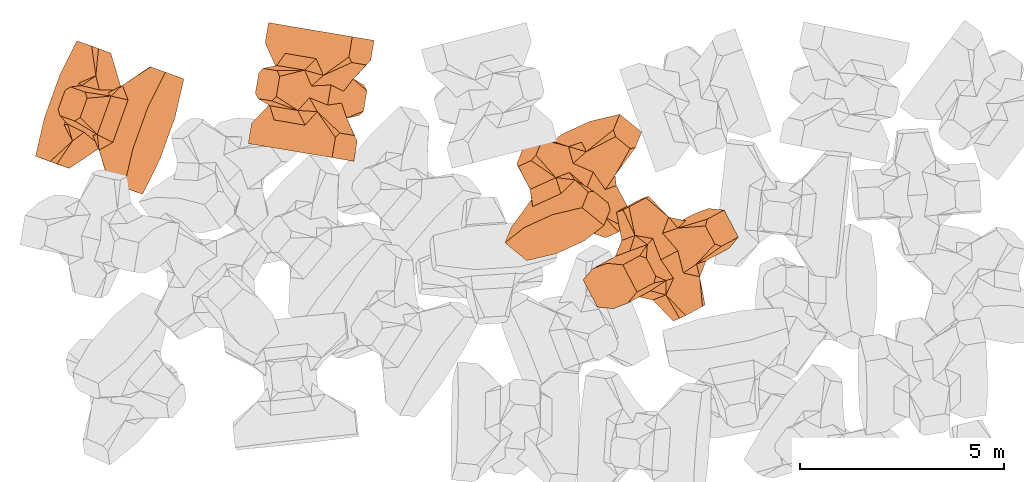
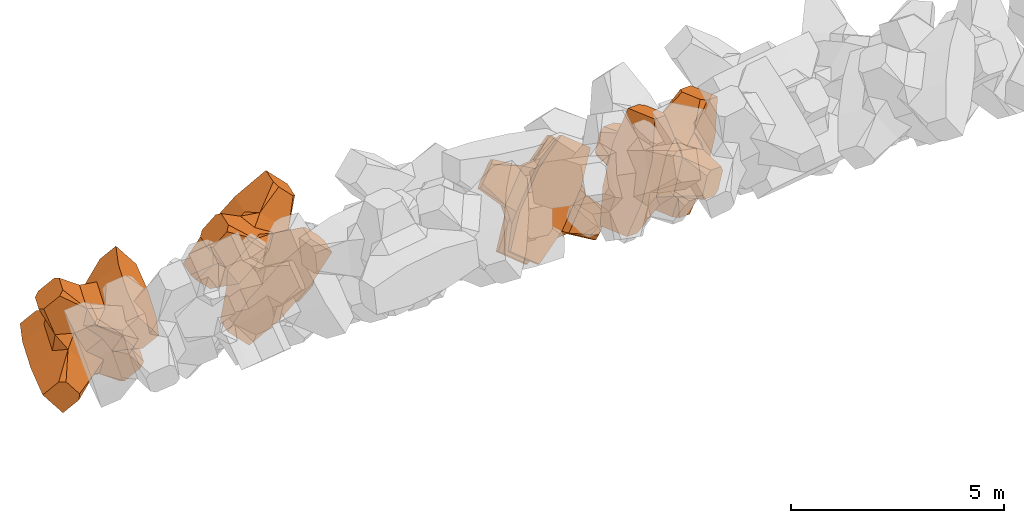
# One storey, part 14 of 17: 4 civil elements.
"""IFC4 building model written with IfcOpenShell, lengths in metres."""

from ifc_helpers import new_model, entity, si_unit, converted_unit, frame, origin_with_axes, origin_2d_with_axis, place, context, subcontext, project, spatial, polygons, element, save


model = new_model("IFC4")

# Units and contexts
model_context = context("Model", 3, precision=1e-05, world=origin_with_axes())
plan_context = context("Plan", 2, precision=1e-05, world=origin_2d_with_axis())
body_context = subcontext(model_context, "Body", "Model", "MODEL_VIEW")
ifc_project = project(units=[si_unit("VOLUMEUNIT", "CUBIC_METRE"), si_unit("LENGTHUNIT", "METRE"), converted_unit("PLANEANGLEUNIT", "degree", entity("IfcReal", 0.0174532925199433), si_unit("PLANEANGLEUNIT", "RADIAN"), dimensions=[0, 0, 0, 0, 0, 0, 0]), si_unit("AREAUNIT", "SQUARE_METRE")], contexts=[model_context, plan_context])

# Site, building, storey
site_placement = place(None, origin_with_axes())
site = spatial("IfcSite", under=ifc_project, at=site_placement)
building_placement = place(site_placement, origin_with_axes())
building = spatial("IfcBuilding", under=site, at=building_placement, Name="Building")
storey_placement = place(building_placement, origin_with_axes())
storey = spatial("IfcBuildingStorey", under=building, at=storey_placement, Name="Storey")

# Civil elements
civil_element_1_placement = place(storey_placement, frame((1.21781599521637, 19.9946975708008, 2.43037390708923), z_axis=(0.604936462853144, -0.22197844929838, -0.764707423762718), x_axis=(0.337829623847278, 0.941188406727842, -0.00596056140921159)))
element("IfcCivilElement", 1, at=civil_element_1_placement, inside=storey, ObjectType="IfcCivilElementType", context=body_context, shape_type="Tessellation", body=[
    polygons([(0.50000011920929, 0.499999940395355, 0.821428716182709), (0.374999821186066, 0.24999988079071, 1.50000023841858), (0.550000011920929, 0.145680576562881, 0.550000131130219), (0.374999821186066, -0.249999940395355, 1.50000023841858), (0.651315808296204, -0.249999940395355, 1.45970560083697e-07), (0.651315808296204, 0.24999988079071, 1.45970560083697e-07), (0.550000011920929, -0.145680651068687, 0.550000131130219), (0.50000011920929, -0.499999940395355, 0.821428716182709), (-0.25, 0.374999672174454, 1.50000023841858), (0.249999970197678, 0.374999672174454, 1.50000023841858), (-0.500000059604645, 0.499999940395355, 0.821428716182709), (-0.550000011920929, 0.824999749660492, 0.550000131130219), (0.550000011920929, 0.824999749660492, 0.550000131130219), (-0.550000011920929, 1.49999964237213, 0.550000131130219), (0.550000011920929, 1.49999964237213, 0.550000131130219), (-0.25, -0.374999910593033, 1.50000023841858), (0.249999970197678, -0.374999910593033, 1.50000023841858), (-0.374999970197678, -0.249999940395355, 1.50000023841858), (-0.374999970197678, 0.24999988079071, 1.50000023841858), (1.5, 0.874999582767487, -0.249999836087227), (1.5, 0.874999582767487, 0.25000011920929), (0.845557510852814, 0.449999779462814, -0.49555516242981), (0.845557510852814, 0.449999779462814, 0.49555516242981), (1.5, 1.49999964237213, -0.374999821186066), (1.5, 1.49999964237213, 0.374999970197678), (1.5, 0.999999701976776, -0.374999821186066), (1.5, 0.999999701976776, 0.374999970197678), (-1.5, 1.49999964237213, -0.374999821186066), (-1.5, 1.49999964237213, 0.374999970197678), (-0.550000011920929, 1.49999964237213, -0.549999833106995), (0.550000011920929, 1.49999964237213, -0.549999833106995), (0.550000011920929, 0.145680576562881, -0.549999833106995), (-0.500000059604645, -0.499999940395355, 0.821428716182709), (-0.550000011920929, -0.145680651068687, 0.550000131130219), (-0.651315808296204, 0.24999988079071, 1.45970560083697e-07), (-0.651315808296204, -0.249999940395355, 1.45970560083697e-07), (-0.550000011920929, 0.145680576562881, 0.550000131130219), (-1.5, 0.874999582767487, 0.25000011920929), (-1.5, 0.874999582767487, -0.249999836087227), (-0.845557391643524, 0.449999779462814, 0.49555516242981), (-0.845557391643524, 0.449999779462814, -0.49555516242981), (-1.5, 0.999999701976776, 0.374999970197678), (-1.5, 0.999999701976776, -0.374999821186066), (-0.550000011920929, 0.145680576562881, -0.549999833106995), (0.550000011920929, -0.824999868869781, 0.550000131130219), (-0.550000011920929, -0.824999868869781, 0.550000131130219), (0.550000011920929, -1.49999964237213, 0.550000131130219), (-0.550000011920929, -1.49999964237213, 0.550000131130219), (1.5, -0.874999821186066, 0.25000011920929), (1.5, -0.874999821186066, -0.249999836087227), (0.845557510852814, -0.449999988079071, 0.49555516242981), (0.845557510852814, -0.449999988079071, -0.49555516242981), (1.5, -1.49999964237213, 0.374999970197678), (1.5, -1.49999964237213, -0.374999821186066), (1.5, -0.99999988079071, 0.374999970197678), (1.5, -0.99999988079071, -0.374999821186066), (0.550000011920929, -1.49999964237213, -0.549999833106995), (-0.550000011920929, -1.49999964237213, -0.549999833106995), (-1.5, -1.49999964237213, -0.374999821186066), (-1.5, -1.49999964237213, 0.374999970197678), (0.550000011920929, -0.145680651068687, -0.549999833106995), (-1.5, -0.874999821186066, -0.249999836087227), (-1.5, -0.874999821186066, 0.25000011920929), (-0.845557391643524, -0.449999988079071, -0.49555516242981), (-0.845557391643524, -0.449999988079071, 0.49555516242981), (-1.5, -0.99999988079071, -0.374999821186066), (-1.5, -0.99999988079071, 0.374999970197678), (-0.550000011920929, -0.145680651068687, -0.549999833106995), (0.50000011920929, -0.499999940395355, -0.821428537368774), (0.374999821186066, -0.249999940395355, -1.49999988079071), (0.374999821186066, 0.24999988079071, -1.49999988079071), (0.50000011920929, 0.499999940395355, -0.821428537368774), (0.249999970197678, 0.374999672174454, -1.49999988079071), (-0.25, 0.374999672174454, -1.49999988079071), (-0.500000059604645, 0.499999940395355, -0.821428537368774), (0.550000011920929, 0.824999749660492, -0.549999833106995), (-0.550000011920929, 0.824999749660492, -0.549999833106995), (0.249999970197678, -0.374999910593033, -1.49999988079071), (-0.25, -0.374999910593033, -1.49999988079071), (-0.374999970197678, -0.249999940395355, -1.49999988079071), (-0.374999970197678, 0.24999988079071, -1.49999988079071), (-0.500000059604645, -0.499999940395355, -0.821428537368774), (-0.550000011920929, -0.824999868869781, -0.549999833106995), (0.550000011920929, -0.824999868869781, -0.549999833106995)], [[[1, 2, 3]], [[3, 2, 4]], [[5, 6, 7]], [[7, 6, 3]], [[7, 3, 8]], [[8, 3, 4]], [[9, 10, 11]], [[11, 10, 1]], [[12, 13, 14]], [[14, 13, 15]], [[16, 17, 18]], [[18, 17, 4]], [[18, 4, 19]], [[19, 4, 2]], [[19, 2, 9]], [[9, 2, 10]], [[20, 21, 22]], [[22, 21, 23]], [[24, 25, 26]], [[26, 25, 27]], [[26, 27, 20]], [[20, 27, 21]], [[23, 27, 13]], [[13, 27, 25]], [[13, 25, 15]], [[28, 29, 30]], [[30, 29, 14]], [[30, 14, 31]], [[31, 14, 15]], [[31, 15, 24]], [[24, 15, 25]], [[21, 27, 23]], [[2, 1, 10]], [[13, 12, 1]], [[1, 12, 11]], [[13, 1, 23]], [[32, 22, 6]], [[6, 22, 23]], [[6, 23, 3]], [[3, 23, 1]], [[33, 18, 34]], [[34, 18, 19]], [[35, 36, 37]], [[37, 36, 34]], [[37, 34, 11]], [[11, 34, 19]], [[38, 39, 40]], [[40, 39, 41]], [[29, 28, 42]], [[42, 28, 43]], [[42, 43, 38]], [[38, 43, 39]], [[14, 29, 12]], [[12, 29, 42]], [[12, 42, 40]], [[40, 42, 38]], [[9, 11, 19]], [[40, 11, 12]], [[37, 40, 35]], [[35, 40, 41]], [[35, 41, 44]], [[11, 40, 37]], [[17, 16, 8]], [[8, 16, 33]], [[45, 46, 47]], [[47, 46, 48]], [[49, 50, 51]], [[51, 50, 52]], [[53, 54, 55]], [[55, 54, 56]], [[55, 56, 49]], [[49, 56, 50]], [[47, 53, 45]], [[45, 53, 55]], [[45, 55, 51]], [[54, 53, 57]], [[57, 53, 47]], [[57, 47, 58]], [[58, 47, 48]], [[58, 48, 59]], [[59, 48, 60]], [[51, 55, 49]], [[17, 8, 4]], [[46, 45, 33]], [[33, 45, 8]], [[51, 8, 45]], [[7, 51, 5]], [[5, 51, 52]], [[5, 52, 61]], [[8, 51, 7]], [[62, 63, 64]], [[64, 63, 65]], [[59, 60, 66]], [[66, 60, 67]], [[66, 67, 62]], [[62, 67, 63]], [[65, 67, 46]], [[46, 67, 60]], [[46, 60, 48]], [[63, 67, 65]], [[18, 33, 16]], [[46, 33, 65]], [[68, 64, 36]], [[36, 64, 65]], [[36, 65, 34]], [[34, 65, 33]], [[69, 70, 61]], [[61, 70, 71]], [[6, 5, 32]], [[32, 5, 61]], [[32, 61, 72]], [[72, 61, 71]], [[73, 74, 72]], [[72, 74, 75]], [[76, 77, 31]], [[31, 77, 30]], [[78, 79, 70]], [[70, 79, 80]], [[70, 80, 71]], [[71, 80, 81]], [[71, 81, 73]], [[73, 81, 74]], [[31, 24, 76]], [[76, 24, 26]], [[76, 26, 22]], [[22, 26, 20]], [[73, 72, 71]], [[77, 76, 75]], [[75, 76, 72]], [[22, 72, 76]], [[72, 22, 32]], [[75, 81, 44]], [[44, 81, 80]], [[36, 35, 68]], [[68, 35, 44]], [[68, 44, 82]], [[82, 44, 80]], [[41, 43, 77]], [[77, 43, 28]], [[77, 28, 30]], [[39, 43, 41]], [[81, 75, 74]], [[77, 75, 41]], [[44, 41, 75]], [[79, 78, 82]], [[82, 78, 69]], [[83, 84, 58]], [[58, 84, 57]], [[52, 56, 84]], [[84, 56, 54]], [[84, 54, 57]], [[50, 56, 52]], [[70, 69, 78]], [[84, 83, 69]], [[69, 83, 82]], [[84, 69, 52]], [[61, 52, 69]], [[58, 59, 83]], [[83, 59, 66]], [[83, 66, 64]], [[64, 66, 62]], [[79, 82, 80]], [[64, 82, 83]], [[82, 64, 68]]], closed=True),
])
civil_element_2_placement = place(storey_placement, frame((6.14419651031494, 20.620777130127, 2.38104557991028), z_axis=(0.710945292411248, -0.119452399341424, -0.693028076985242), x_axis=(-0.683448188492928, 0.11483239265488, -0.720910601422181)))
element("IfcCivilElement", 2, at=civil_element_2_placement, inside=storey, ObjectType="IfcCivilElementType", context=body_context, shape_type="Tessellation", body=[
    polygons([(0.5, 0.500000059604645, 0.821428596973419), (0.374999761581421, 0.249999940395355, 1.49999988079071), (0.549999892711639, 0.145680621266365, 0.550000011920929), (0.374999761581421, -0.250000029802322, 1.49999988079071), (0.651315689086914, -0.250000029802322, 1.45970531661987e-07), (0.651315689086914, 0.249999940395355, 1.45970531661987e-07), (0.549999892711639, -0.145680695772171, 0.550000011920929), (0.5, -0.500000059604645, 0.821428596973419), (-0.249999955296516, 0.374999791383743, 1.49999988079071), (0.249999910593033, 0.374999791383743, 1.49999988079071), (-0.499999940395355, 0.500000059604645, 0.821428596973419), (-0.549999892711639, 0.824999988079071, 0.550000011920929), (0.549999892711639, 0.824999988079071, 0.550000011920929), (-0.549999892711639, 1.5, 0.550000011920929), (0.549999892711639, 1.5, 0.550000011920929), (-0.249999955296516, -0.375, 1.49999988079071), (0.249999910593033, -0.375, 1.49999988079071), (-0.374999910593033, -0.250000029802322, 1.49999988079071), (-0.374999910593033, 0.249999940395355, 1.49999988079071), (1.49999976158142, 0.87499988079071, -0.249999791383743), (1.49999976158142, 0.87499988079071, 0.250000089406967), (0.845557391643524, 0.449999898672104, -0.495555073022842), (0.845557391643524, 0.449999898672104, 0.495555073022842), (1.49999976158142, 1.5, -0.374999761581421), (1.49999976158142, 1.5, 0.374999910593033), (1.49999976158142, 1.0, -0.374999761581421), (1.49999976158142, 1.0, 0.374999910593033), (-1.49999976158142, 1.5, -0.374999761581421), (-1.49999976158142, 1.5, 0.374999910593033), (-0.549999892711639, 1.5, -0.549999713897705), (0.549999892711639, 1.5, -0.549999713897705), (0.549999892711639, 0.145680621266365, -0.549999713897705), (-0.499999940395355, -0.500000059604645, 0.821428596973419), (-0.549999892711639, -0.145680695772171, 0.550000011920929), (-0.651315689086914, 0.249999940395355, 1.45970531661987e-07), (-0.651315689086914, -0.250000029802322, 1.45970531661987e-07), (-0.549999892711639, 0.145680621266365, 0.550000011920929), (-1.49999976158142, 0.87499988079071, 0.250000089406967), (-1.49999976158142, 0.87499988079071, -0.249999791383743), (-0.84555721282959, 0.449999898672104, 0.495555073022842), (-0.84555721282959, 0.449999898672104, -0.495555073022842), (-1.49999976158142, 1.0, 0.374999910593033), (-1.49999976158142, 1.0, -0.374999761581421), (-0.549999892711639, 0.145680621266365, -0.549999713897705), (0.549999892711639, -0.825000107288361, 0.550000011920929), (-0.549999892711639, -0.825000107288361, 0.550000011920929), (0.549999892711639, -1.5, 0.550000011920929), (-0.549999892711639, -1.5, 0.550000011920929), (1.49999976158142, -0.875000059604645, 0.250000089406967), (1.49999976158142, -0.875000059604645, -0.249999791383743), (0.845557391643524, -0.450000137090683, 0.495555073022842), (0.845557391643524, -0.450000137090683, -0.495555073022842), (1.49999976158142, -1.5, 0.374999910593033), (1.49999976158142, -1.5, -0.374999761581421), (1.49999976158142, -1.00000011920929, 0.374999910593033), (1.49999976158142, -1.00000011920929, -0.374999761581421), (0.549999892711639, -1.5, -0.549999713897705), (-0.549999892711639, -1.5, -0.549999713897705), (-1.49999976158142, -1.5, -0.374999761581421), (-1.49999976158142, -1.5, 0.374999910593033), (0.549999892711639, -0.145680695772171, -0.549999713897705), (-1.49999976158142, -0.875000059604645, -0.249999791383743), (-1.49999976158142, -0.875000059604645, 0.250000089406967), (-0.84555721282959, -0.450000137090683, -0.495555073022842), (-0.84555721282959, -0.450000137090683, 0.495555073022842), (-1.49999976158142, -1.00000011920929, -0.374999761581421), (-1.49999976158142, -1.00000011920929, 0.374999910593033), (-0.549999892711639, -0.145680695772171, -0.549999713897705), (0.5, -0.500000059604645, -0.82142835855484), (0.374999761581421, -0.250000029802322, -1.49999964237213), (0.374999761581421, 0.249999940395355, -1.49999964237213), (0.5, 0.500000059604645, -0.82142835855484), (0.249999910593033, 0.374999791383743, -1.49999964237213), (-0.249999955296516, 0.374999791383743, -1.49999964237213), (-0.499999940395355, 0.500000059604645, -0.82142835855484), (0.549999892711639, 0.824999988079071, -0.549999713897705), (-0.549999892711639, 0.824999988079071, -0.549999713897705), (0.249999910593033, -0.375, -1.49999964237213), (-0.249999955296516, -0.375, -1.49999964237213), (-0.374999910593033, -0.250000029802322, -1.49999964237213), (-0.374999910593033, 0.249999940395355, -1.49999964237213), (-0.499999940395355, -0.500000059604645, -0.82142835855484), (-0.549999892711639, -0.825000107288361, -0.549999713897705), (0.549999892711639, -0.825000107288361, -0.549999713897705)], [[[1, 2, 3]], [[3, 2, 4]], [[5, 6, 7]], [[7, 6, 3]], [[7, 3, 8]], [[8, 3, 4]], [[9, 10, 11]], [[11, 10, 1]], [[12, 13, 14]], [[14, 13, 15]], [[16, 17, 18]], [[18, 17, 4]], [[18, 4, 19]], [[19, 4, 2]], [[19, 2, 9]], [[9, 2, 10]], [[20, 21, 22]], [[22, 21, 23]], [[24, 25, 26]], [[26, 25, 27]], [[26, 27, 20]], [[20, 27, 21]], [[23, 27, 13]], [[13, 27, 25]], [[13, 25, 15]], [[28, 29, 30]], [[30, 29, 14]], [[30, 14, 31]], [[31, 14, 15]], [[31, 15, 24]], [[24, 15, 25]], [[21, 27, 23]], [[2, 1, 10]], [[13, 12, 1]], [[1, 12, 11]], [[13, 1, 23]], [[32, 22, 6]], [[6, 22, 23]], [[6, 23, 3]], [[3, 23, 1]], [[33, 18, 34]], [[34, 18, 19]], [[35, 36, 37]], [[37, 36, 34]], [[37, 34, 11]], [[11, 34, 19]], [[38, 39, 40]], [[40, 39, 41]], [[29, 28, 42]], [[42, 28, 43]], [[42, 43, 38]], [[38, 43, 39]], [[14, 29, 12]], [[12, 29, 42]], [[12, 42, 40]], [[40, 42, 38]], [[9, 11, 19]], [[40, 11, 12]], [[37, 40, 35]], [[35, 40, 41]], [[35, 41, 44]], [[11, 40, 37]], [[17, 16, 8]], [[8, 16, 33]], [[45, 46, 47]], [[47, 46, 48]], [[49, 50, 51]], [[51, 50, 52]], [[53, 54, 55]], [[55, 54, 56]], [[55, 56, 49]], [[49, 56, 50]], [[47, 53, 45]], [[45, 53, 55]], [[45, 55, 51]], [[54, 53, 57]], [[57, 53, 47]], [[57, 47, 58]], [[58, 47, 48]], [[58, 48, 59]], [[59, 48, 60]], [[51, 55, 49]], [[17, 8, 4]], [[46, 45, 33]], [[33, 45, 8]], [[51, 8, 45]], [[7, 51, 5]], [[5, 51, 52]], [[5, 52, 61]], [[8, 51, 7]], [[62, 63, 64]], [[64, 63, 65]], [[59, 60, 66]], [[66, 60, 67]], [[66, 67, 62]], [[62, 67, 63]], [[65, 67, 46]], [[46, 67, 60]], [[46, 60, 48]], [[63, 67, 65]], [[18, 33, 16]], [[46, 33, 65]], [[68, 64, 36]], [[36, 64, 65]], [[36, 65, 34]], [[34, 65, 33]], [[69, 70, 61]], [[61, 70, 71]], [[6, 5, 32]], [[32, 5, 61]], [[32, 61, 72]], [[72, 61, 71]], [[73, 74, 72]], [[72, 74, 75]], [[76, 77, 31]], [[31, 77, 30]], [[78, 79, 70]], [[70, 79, 80]], [[70, 80, 71]], [[71, 80, 81]], [[71, 81, 73]], [[73, 81, 74]], [[31, 24, 76]], [[76, 24, 26]], [[76, 26, 22]], [[22, 26, 20]], [[73, 72, 71]], [[77, 76, 75]], [[75, 76, 72]], [[22, 72, 76]], [[72, 22, 32]], [[75, 81, 44]], [[44, 81, 80]], [[36, 35, 68]], [[68, 35, 44]], [[68, 44, 82]], [[82, 44, 80]], [[41, 43, 77]], [[77, 43, 28]], [[77, 28, 30]], [[39, 43, 41]], [[81, 75, 74]], [[77, 75, 41]], [[44, 41, 75]], [[79, 78, 82]], [[82, 78, 69]], [[83, 84, 58]], [[58, 84, 57]], [[52, 56, 84]], [[84, 56, 54]], [[84, 54, 57]], [[50, 56, 52]], [[70, 69, 78]], [[84, 83, 69]], [[69, 83, 82]], [[84, 69, 52]], [[61, 52, 69]], [[58, 59, 83]], [[83, 59, 66]], [[83, 66, 64]], [[64, 66, 62]], [[79, 82, 80]], [[64, 82, 83]], [[82, 64, 68]]], closed=True),
])
civil_element_3_placement = place(storey_placement, frame((12.5536365509033, 18.285062789917, 3.22644257545471), z_axis=(0.713986803976341, -0.58124350683661, -0.390357310048025), x_axis=(-0.628884665672109, -0.287306305344408, -0.722467413930777)))
element("IfcCivilElement", 3, at=civil_element_3_placement, inside=storey, ObjectType="IfcCivilElementType", context=body_context, shape_type="Tessellation", body=[
    polygons([(0.500000059604645, 0.500000059604645, 0.821428835391998), (0.374999791383743, 0.249999940395355, 1.50000035762787), (0.549999952316284, 0.145680621266365, 0.550000190734863), (0.374999791383743, -0.250000029802322, 1.50000035762787), (0.651315748691559, -0.250000029802322, 1.45970574294552e-07), (0.651315748691559, 0.249999940395355, 1.45970574294552e-07), (0.549999952316284, -0.145680695772171, 0.550000190734863), (0.500000059604645, -0.500000059604645, 0.821428835391998), (-0.249999970197678, 0.374999791383743, 1.50000035762787), (0.249999940395355, 0.374999791383743, 1.50000035762787), (-0.5, 0.500000059604645, 0.821428835391998), (-0.549999952316284, 0.824999988079071, 0.550000190734863), (0.549999952316284, 0.824999988079071, 0.550000190734863), (-0.549999952316284, 1.5, 0.550000190734863), (0.549999952316284, 1.5, 0.550000190734863), (-0.249999970197678, -0.375, 1.50000035762787), (0.249999940395355, -0.375, 1.50000035762787), (-0.374999940395355, -0.250000029802322, 1.50000035762787), (-0.374999940395355, 0.249999940395355, 1.50000035762787), (1.49999988079071, 0.87499988079071, -0.249999865889549), (1.49999988079071, 0.87499988079071, 0.250000149011612), (0.845557451248169, 0.449999898672104, -0.495555222034454), (0.845557451248169, 0.449999898672104, 0.495555222034454), (1.49999988079071, 1.5, -0.374999850988388), (1.49999988079071, 1.5, 0.375), (1.49999988079071, 1.0, -0.374999850988388), (1.49999988079071, 1.0, 0.375), (-1.49999988079071, 1.5, -0.374999850988388), (-1.49999988079071, 1.5, 0.375), (-0.549999952316284, 1.5, -0.549999892711639), (0.549999952316284, 1.5, -0.549999892711639), (0.549999952316284, 0.145680621266365, -0.549999892711639), (-0.5, -0.500000059604645, 0.821428835391998), (-0.549999952316284, -0.145680695772171, 0.550000190734863), (-0.651315748691559, 0.249999940395355, 1.45970574294552e-07), (-0.651315748691559, -0.250000029802322, 1.45970574294552e-07), (-0.549999952316284, 0.145680621266365, 0.550000190734863), (-1.49999988079071, 0.87499988079071, 0.250000149011612), (-1.49999988079071, 0.87499988079071, -0.249999865889549), (-0.845557332038879, 0.449999898672104, 0.495555222034454), (-0.845557332038879, 0.449999898672104, -0.495555222034454), (-1.49999988079071, 1.0, 0.375), (-1.49999988079071, 1.0, -0.374999850988388), (-0.549999952316284, 0.145680621266365, -0.549999892711639), (0.549999952316284, -0.825000107288361, 0.550000190734863), (-0.549999952316284, -0.825000107288361, 0.550000190734863), (0.549999952316284, -1.5, 0.550000190734863), (-0.549999952316284, -1.5, 0.550000190734863), (1.49999988079071, -0.875000059604645, 0.250000149011612), (1.49999988079071, -0.875000059604645, -0.249999865889549), (0.845557451248169, -0.450000137090683, 0.495555222034454), (0.845557451248169, -0.450000137090683, -0.495555222034454), (1.49999988079071, -1.5, 0.375), (1.49999988079071, -1.5, -0.374999850988388), (1.49999988079071, -1.00000011920929, 0.375), (1.49999988079071, -1.00000011920929, -0.374999850988388), (0.549999952316284, -1.5, -0.549999892711639), (-0.549999952316284, -1.5, -0.549999892711639), (-1.49999988079071, -1.5, -0.374999850988388), (-1.49999988079071, -1.5, 0.375), (0.549999952316284, -0.145680695772171, -0.549999892711639), (-1.49999988079071, -0.875000059604645, -0.249999865889549), (-1.49999988079071, -0.875000059604645, 0.250000149011612), (-0.845557332038879, -0.450000137090683, -0.495555222034454), (-0.845557332038879, -0.450000137090683, 0.495555222034454), (-1.49999988079071, -1.00000011920929, -0.374999850988388), (-1.49999988079071, -1.00000011920929, 0.375), (-0.549999952316284, -0.145680695772171, -0.549999892711639), (0.500000059604645, -0.500000059604645, -0.821428596973419), (0.374999791383743, -0.250000029802322, -1.5), (0.374999791383743, 0.249999940395355, -1.5), (0.500000059604645, 0.500000059604645, -0.821428596973419), (0.249999940395355, 0.374999791383743, -1.5), (-0.249999970197678, 0.374999791383743, -1.5), (-0.5, 0.500000059604645, -0.821428596973419), (0.549999952316284, 0.824999988079071, -0.549999892711639), (-0.549999952316284, 0.824999988079071, -0.549999892711639), (0.249999940395355, -0.375, -1.5), (-0.249999970197678, -0.375, -1.5), (-0.374999940395355, -0.250000029802322, -1.5), (-0.374999940395355, 0.249999940395355, -1.5), (-0.5, -0.500000059604645, -0.821428596973419), (-0.549999952316284, -0.825000107288361, -0.549999892711639), (0.549999952316284, -0.825000107288361, -0.549999892711639)], [[[1, 2, 3]], [[3, 2, 4]], [[5, 6, 7]], [[7, 6, 3]], [[7, 3, 8]], [[8, 3, 4]], [[9, 10, 11]], [[11, 10, 1]], [[12, 13, 14]], [[14, 13, 15]], [[16, 17, 18]], [[18, 17, 4]], [[18, 4, 19]], [[19, 4, 2]], [[19, 2, 9]], [[9, 2, 10]], [[20, 21, 22]], [[22, 21, 23]], [[24, 25, 26]], [[26, 25, 27]], [[26, 27, 20]], [[20, 27, 21]], [[23, 27, 13]], [[13, 27, 25]], [[13, 25, 15]], [[28, 29, 30]], [[30, 29, 14]], [[30, 14, 31]], [[31, 14, 15]], [[31, 15, 24]], [[24, 15, 25]], [[21, 27, 23]], [[2, 1, 10]], [[13, 12, 1]], [[1, 12, 11]], [[13, 1, 23]], [[32, 22, 6]], [[6, 22, 23]], [[6, 23, 3]], [[3, 23, 1]], [[33, 18, 34]], [[34, 18, 19]], [[35, 36, 37]], [[37, 36, 34]], [[37, 34, 11]], [[11, 34, 19]], [[38, 39, 40]], [[40, 39, 41]], [[29, 28, 42]], [[42, 28, 43]], [[42, 43, 38]], [[38, 43, 39]], [[14, 29, 12]], [[12, 29, 42]], [[12, 42, 40]], [[40, 42, 38]], [[9, 11, 19]], [[40, 11, 12]], [[37, 40, 35]], [[35, 40, 41]], [[35, 41, 44]], [[11, 40, 37]], [[17, 16, 8]], [[8, 16, 33]], [[45, 46, 47]], [[47, 46, 48]], [[49, 50, 51]], [[51, 50, 52]], [[53, 54, 55]], [[55, 54, 56]], [[55, 56, 49]], [[49, 56, 50]], [[47, 53, 45]], [[45, 53, 55]], [[45, 55, 51]], [[54, 53, 57]], [[57, 53, 47]], [[57, 47, 58]], [[58, 47, 48]], [[58, 48, 59]], [[59, 48, 60]], [[51, 55, 49]], [[17, 8, 4]], [[46, 45, 33]], [[33, 45, 8]], [[51, 8, 45]], [[7, 51, 5]], [[5, 51, 52]], [[5, 52, 61]], [[8, 51, 7]], [[62, 63, 64]], [[64, 63, 65]], [[59, 60, 66]], [[66, 60, 67]], [[66, 67, 62]], [[62, 67, 63]], [[65, 67, 46]], [[46, 67, 60]], [[46, 60, 48]], [[63, 67, 65]], [[18, 33, 16]], [[46, 33, 65]], [[68, 64, 36]], [[36, 64, 65]], [[36, 65, 34]], [[34, 65, 33]], [[69, 70, 61]], [[61, 70, 71]], [[6, 5, 32]], [[32, 5, 61]], [[32, 61, 72]], [[72, 61, 71]], [[73, 74, 72]], [[72, 74, 75]], [[76, 77, 31]], [[31, 77, 30]], [[78, 79, 70]], [[70, 79, 80]], [[70, 80, 71]], [[71, 80, 81]], [[71, 81, 73]], [[73, 81, 74]], [[31, 24, 76]], [[76, 24, 26]], [[76, 26, 22]], [[22, 26, 20]], [[73, 72, 71]], [[77, 76, 75]], [[75, 76, 72]], [[22, 72, 76]], [[72, 22, 32]], [[75, 81, 44]], [[44, 81, 80]], [[36, 35, 68]], [[68, 35, 44]], [[68, 44, 82]], [[82, 44, 80]], [[41, 43, 77]], [[77, 43, 28]], [[77, 28, 30]], [[39, 43, 41]], [[81, 75, 74]], [[77, 75, 41]], [[44, 41, 75]], [[79, 78, 82]], [[82, 78, 69]], [[83, 84, 58]], [[58, 84, 57]], [[52, 56, 84]], [[84, 56, 54]], [[84, 54, 57]], [[50, 56, 52]], [[70, 69, 78]], [[84, 83, 69]], [[69, 83, 82]], [[84, 69, 52]], [[61, 52, 69]], [[58, 59, 83]], [[83, 59, 66]], [[83, 66, 64]], [[64, 66, 62]], [[79, 82, 80]], [[64, 82, 83]], [[82, 64, 68]]], closed=True),
])
civil_element_4_placement = place(storey_placement, frame((14.6934280395508, 16.5473155975342, 4.6354866027832), z_axis=(0.46161999490047, -0.886007114629039, -0.0435703240154928), x_axis=(-0.323060964372249, -0.12216878863691, -0.938459589104327)))
element("IfcCivilElement", 4, at=civil_element_4_placement, inside=storey, ObjectType="IfcCivilElementType", context=body_context, shape_type="Tessellation", body=[
    polygons([(0.500000059604645, 0.5, 0.821428716182709), (0.374999791383743, 0.249999925494194, 1.50000023841858), (0.549999952316284, 0.145680606365204, 0.550000131130219), (0.374999791383743, -0.25, 1.50000023841858), (0.651315748691559, -0.25, 1.45970560083697e-07), (0.651315748691559, 0.249999925494194, 1.45970560083697e-07), (0.549999952316284, -0.14568068087101, 0.550000131130219), (0.500000059604645, -0.5, 0.821428716182709), (-0.249999970197678, 0.374999761581421, 1.50000023841858), (0.249999940395355, 0.374999761581421, 1.50000023841858), (-0.5, 0.5, 0.821428716182709), (-0.549999952316284, 0.824999928474426, 0.550000131130219), (0.549999952316284, 0.824999928474426, 0.550000131130219), (-0.549999952316284, 1.49999988079071, 0.550000131130219), (0.549999952316284, 1.49999988079071, 0.550000131130219), (-0.249999970197678, -0.374999970197678, 1.50000023841858), (0.249999940395355, -0.374999970197678, 1.50000023841858), (-0.374999940395355, -0.25, 1.50000023841858), (-0.374999940395355, 0.249999925494194, 1.50000023841858), (1.49999988079071, 0.874999761581421, -0.249999836087227), (1.49999988079071, 0.874999761581421, 0.25000011920929), (0.845557451248169, 0.449999868869781, -0.49555516242981), (0.845557451248169, 0.449999868869781, 0.49555516242981), (1.49999988079071, 1.49999988079071, -0.374999821186066), (1.49999988079071, 1.49999988079071, 0.374999970197678), (1.49999988079071, 0.99999988079071, -0.374999821186066), (1.49999988079071, 0.99999988079071, 0.374999970197678), (-1.49999988079071, 1.49999988079071, -0.374999821186066), (-1.49999988079071, 1.49999988079071, 0.374999970197678), (-0.549999952316284, 1.49999988079071, -0.549999833106995), (0.549999952316284, 1.49999988079071, -0.549999833106995), (0.549999952316284, 0.145680606365204, -0.549999833106995), (-0.5, -0.5, 0.821428716182709), (-0.549999952316284, -0.14568068087101, 0.550000131130219), (-0.651315748691559, 0.249999925494194, 1.45970560083697e-07), (-0.651315748691559, -0.25, 1.45970560083697e-07), (-0.549999952316284, 0.145680606365204, 0.550000131130219), (-1.49999988079071, 0.874999761581421, 0.25000011920929), (-1.49999988079071, 0.874999761581421, -0.249999836087227), (-0.845557332038879, 0.449999868869781, 0.49555516242981), (-0.845557332038879, 0.449999868869781, -0.49555516242981), (-1.49999988079071, 0.99999988079071, 0.374999970197678), (-1.49999988079071, 0.99999988079071, -0.374999821186066), (-0.549999952316284, 0.145680606365204, -0.549999833106995), (0.549999952316284, -0.825000047683716, 0.550000131130219), (-0.549999952316284, -0.825000047683716, 0.550000131130219), (0.549999952316284, -1.49999988079071, 0.550000131130219), (-0.549999952316284, -1.49999988079071, 0.550000131130219), (1.49999988079071, -0.875, 0.25000011920929), (1.49999988079071, -0.875, -0.249999836087227), (0.845557451248169, -0.450000077486038, 0.49555516242981), (0.845557451248169, -0.450000077486038, -0.49555516242981), (1.49999988079071, -1.49999988079071, 0.374999970197678), (1.49999988079071, -1.49999988079071, -0.374999821186066), (1.49999988079071, -1.0, 0.374999970197678), (1.49999988079071, -1.0, -0.374999821186066), (0.549999952316284, -1.49999988079071, -0.549999833106995), (-0.549999952316284, -1.49999988079071, -0.549999833106995), (-1.49999988079071, -1.49999988079071, -0.374999821186066), (-1.49999988079071, -1.49999988079071, 0.374999970197678), (0.549999952316284, -0.14568068087101, -0.549999833106995), (-1.49999988079071, -0.875, -0.249999836087227), (-1.49999988079071, -0.875, 0.25000011920929), (-0.845557332038879, -0.450000077486038, -0.49555516242981), (-0.845557332038879, -0.450000077486038, 0.49555516242981), (-1.49999988079071, -1.0, -0.374999821186066), (-1.49999988079071, -1.0, 0.374999970197678), (-0.549999952316284, -0.14568068087101, -0.549999833106995), (0.500000059604645, -0.5, -0.821428537368774), (0.374999791383743, -0.25, -1.49999988079071), (0.374999791383743, 0.249999925494194, -1.49999988079071), (0.500000059604645, 0.5, -0.821428537368774), (0.249999940395355, 0.374999761581421, -1.49999988079071), (-0.249999970197678, 0.374999761581421, -1.49999988079071), (-0.5, 0.5, -0.821428537368774), (0.549999952316284, 0.824999928474426, -0.549999833106995), (-0.549999952316284, 0.824999928474426, -0.549999833106995), (0.249999940395355, -0.374999970197678, -1.49999988079071), (-0.249999970197678, -0.374999970197678, -1.49999988079071), (-0.374999940395355, -0.25, -1.49999988079071), (-0.374999940395355, 0.249999925494194, -1.49999988079071), (-0.5, -0.5, -0.821428537368774), (-0.549999952316284, -0.825000047683716, -0.549999833106995), (0.549999952316284, -0.825000047683716, -0.549999833106995)], [[[1, 2, 3]], [[3, 2, 4]], [[5, 6, 7]], [[7, 6, 3]], [[7, 3, 8]], [[8, 3, 4]], [[9, 10, 11]], [[11, 10, 1]], [[12, 13, 14]], [[14, 13, 15]], [[16, 17, 18]], [[18, 17, 4]], [[18, 4, 19]], [[19, 4, 2]], [[19, 2, 9]], [[9, 2, 10]], [[20, 21, 22]], [[22, 21, 23]], [[24, 25, 26]], [[26, 25, 27]], [[26, 27, 20]], [[20, 27, 21]], [[23, 27, 13]], [[13, 27, 25]], [[13, 25, 15]], [[28, 29, 30]], [[30, 29, 14]], [[30, 14, 31]], [[31, 14, 15]], [[31, 15, 24]], [[24, 15, 25]], [[21, 27, 23]], [[2, 1, 10]], [[13, 12, 1]], [[1, 12, 11]], [[13, 1, 23]], [[32, 22, 6]], [[6, 22, 23]], [[6, 23, 3]], [[3, 23, 1]], [[33, 18, 34]], [[34, 18, 19]], [[35, 36, 37]], [[37, 36, 34]], [[37, 34, 11]], [[11, 34, 19]], [[38, 39, 40]], [[40, 39, 41]], [[29, 28, 42]], [[42, 28, 43]], [[42, 43, 38]], [[38, 43, 39]], [[14, 29, 12]], [[12, 29, 42]], [[12, 42, 40]], [[40, 42, 38]], [[9, 11, 19]], [[40, 11, 12]], [[37, 40, 35]], [[35, 40, 41]], [[35, 41, 44]], [[11, 40, 37]], [[17, 16, 8]], [[8, 16, 33]], [[45, 46, 47]], [[47, 46, 48]], [[49, 50, 51]], [[51, 50, 52]], [[53, 54, 55]], [[55, 54, 56]], [[55, 56, 49]], [[49, 56, 50]], [[47, 53, 45]], [[45, 53, 55]], [[45, 55, 51]], [[54, 53, 57]], [[57, 53, 47]], [[57, 47, 58]], [[58, 47, 48]], [[58, 48, 59]], [[59, 48, 60]], [[51, 55, 49]], [[17, 8, 4]], [[46, 45, 33]], [[33, 45, 8]], [[51, 8, 45]], [[7, 51, 5]], [[5, 51, 52]], [[5, 52, 61]], [[8, 51, 7]], [[62, 63, 64]], [[64, 63, 65]], [[59, 60, 66]], [[66, 60, 67]], [[66, 67, 62]], [[62, 67, 63]], [[65, 67, 46]], [[46, 67, 60]], [[46, 60, 48]], [[63, 67, 65]], [[18, 33, 16]], [[46, 33, 65]], [[68, 64, 36]], [[36, 64, 65]], [[36, 65, 34]], [[34, 65, 33]], [[69, 70, 61]], [[61, 70, 71]], [[6, 5, 32]], [[32, 5, 61]], [[32, 61, 72]], [[72, 61, 71]], [[73, 74, 72]], [[72, 74, 75]], [[76, 77, 31]], [[31, 77, 30]], [[78, 79, 70]], [[70, 79, 80]], [[70, 80, 71]], [[71, 80, 81]], [[71, 81, 73]], [[73, 81, 74]], [[31, 24, 76]], [[76, 24, 26]], [[76, 26, 22]], [[22, 26, 20]], [[73, 72, 71]], [[77, 76, 75]], [[75, 76, 72]], [[22, 72, 76]], [[72, 22, 32]], [[75, 81, 44]], [[44, 81, 80]], [[36, 35, 68]], [[68, 35, 44]], [[68, 44, 82]], [[82, 44, 80]], [[41, 43, 77]], [[77, 43, 28]], [[77, 28, 30]], [[39, 43, 41]], [[81, 75, 74]], [[77, 75, 41]], [[44, 41, 75]], [[79, 78, 82]], [[82, 78, 69]], [[83, 84, 58]], [[58, 84, 57]], [[52, 56, 84]], [[84, 56, 54]], [[84, 54, 57]], [[50, 56, 52]], [[70, 69, 78]], [[84, 83, 69]], [[69, 83, 82]], [[84, 69, 52]], [[61, 52, 69]], [[58, 59, 83]], [[83, 59, 66]], [[83, 66, 64]], [[64, 66, 62]], [[79, 82, 80]], [[64, 82, 83]], [[82, 64, 68]]], closed=True),
])

save(model, "model.ifc")
